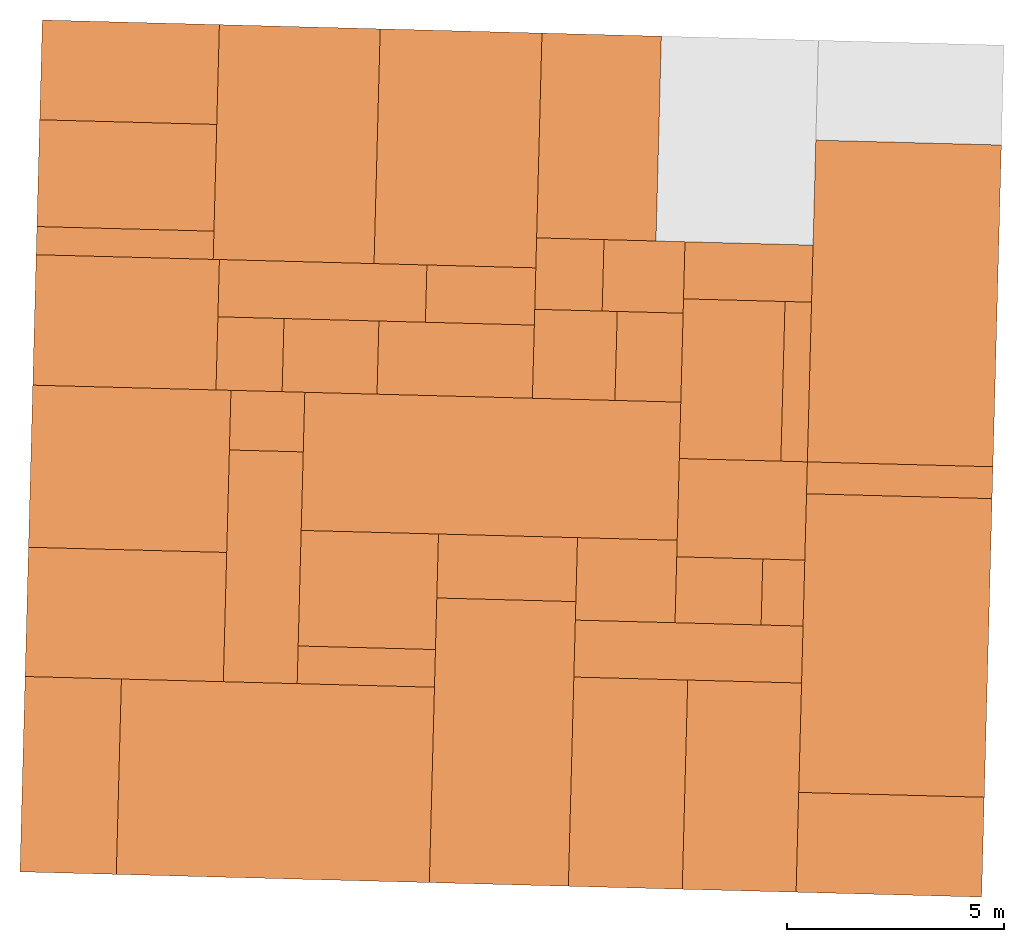
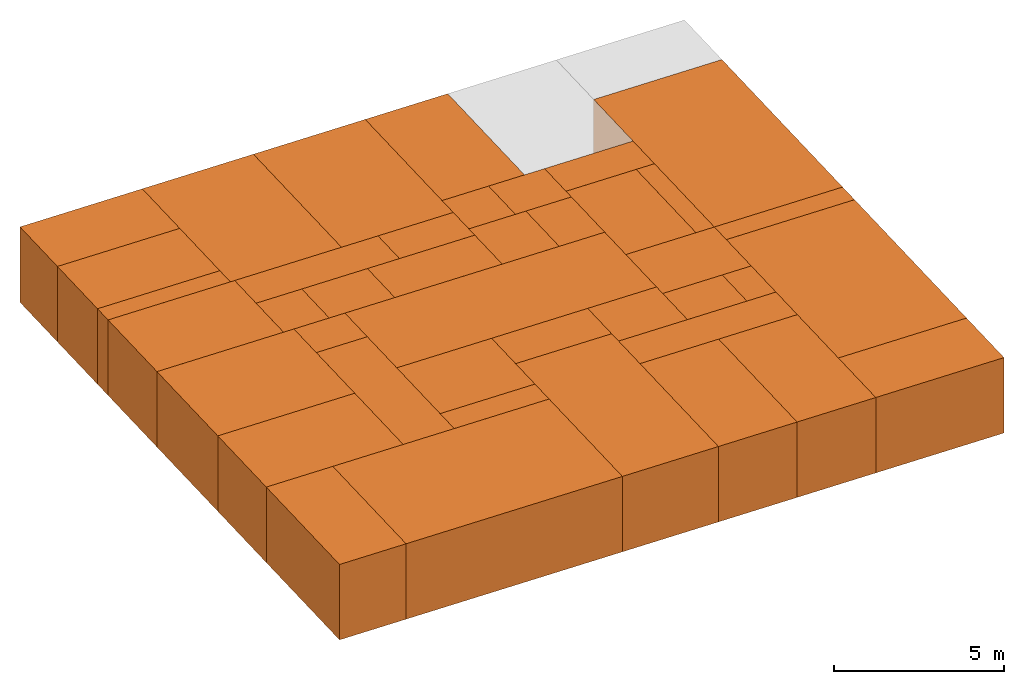
# One storey, part 1 of 2: 41 proxies.
"""IFC2X3 building model written with IfcOpenShell, lengths in metres."""

import ifcopenshell
import ifcopenshell.guid

model = None  # the IFC model being written
_history = None  # IfcOwnerHistory: only IFC2X3 demands one
_inside = {}  # id of a spatial element -> (the spatial element, [elements in it])
_under = {}  # id of a project, library or spatial element -> (it, [spatial elements below it])
_declared = {}  # id of a project -> (the project, [libraries it declares])
_typed = {}  # id of a type object -> (the type object, [elements of that type])
_made_of = {}  # id of a material, layer set ... -> (it, [elements and type objects made of it])


def new_model(schema):
    """Start an empty IFC model of exactly this schema.

    Asked for "IFC4X3", IfcOpenShell would pick the latest addendum, in which some entities
    have other attributes; the version numbers below select the first issue.
    IFC2X3 requires an IfcOwnerHistory on every rooted entity: one is made here for all.
    """
    global model, _history
    if schema == "IFC4X3":
        model = ifcopenshell.file(schema_version=(4, 3, 0, 0))
    else:
        model = ifcopenshell.file(schema=schema)
    _inside.clear()
    _under.clear()
    _declared.clear()
    _typed.clear()
    _made_of.clear()
    _history = None
    if model.schema == "IFC2X3":
        org = make("IfcOrganization", Name="unknown")
        user = make(
            "IfcPersonAndOrganization",
            ThePerson=make("IfcPerson", FamilyName="unknown"),
            TheOrganization=org,
        )
        app = make(
            "IfcApplication",
            ApplicationDeveloper=org,
            Version="unknown",
            ApplicationFullName="unknown",
            ApplicationIdentifier="unknown",
        )
        _history = make(
            "IfcOwnerHistory",
            OwningUser=user,
            OwningApplication=app,
            ChangeAction="ADDED",
            CreationDate=0,
        )
    return model


def make(cls, **values):
    """One entity of the class cls with the attributes given. An attribute that is None is left unset."""
    return model.create_entity(
        cls, **{name: value for name, value in values.items() if value is not None}
    )


def entity(cls, *values):
    """Any entity or typed value of the class cls, its attributes in the order of the schema. None: left unset."""
    e = model.create_entity(cls)
    for i, value in enumerate(values):
        if value is not None:
            e[i] = value
    return e


def rooted(cls, **values):
    """An entity with a GlobalId (a new one), such as an element, a storey or a relation."""
    return make(cls, GlobalId=ifcopenshell.guid.new(), OwnerHistory=_history, **values)


def si_unit(unit_type, name, prefix=None):
    """IfcSIUnit, for example si_unit("LENGTHUNIT", "METRE", prefix="MILLI")."""
    return make("IfcSIUnit", UnitType=unit_type, Prefix=prefix, Name=name)


def converted_unit(unit_type, name, factor, base, dimensions=None, offset=None):
    """IfcConversionBasedUnit, such as the inch: factor (a typed value) times the base unit."""
    return make(
        "IfcConversionBasedUnit"
        if offset is None
        else "IfcConversionBasedUnitWithOffset",
        ConversionOffset=offset,
        Dimensions=None
        if dimensions is None
        else entity("IfcDimensionalExponents", *dimensions),
        UnitType=unit_type,
        Name=name,
        ConversionFactor=make(
            "IfcMeasureWithUnit", ValueComponent=factor, UnitComponent=base
        ),
    )


def derived_unit(unit_type, elements):
    """IfcDerivedUnit: a product of units, each with its exponent."""
    return make(
        "IfcDerivedUnit",
        Elements=[
            make("IfcDerivedUnitElement", Unit=unit, Exponent=power)
            for unit, power in elements
        ],
        UnitType=unit_type,
    )


def assignment(units):
    """IfcUnitAssignment: the units of a project."""
    return None if units is None else make("IfcUnitAssignment", Units=units)


def point(xyz):
    """IfcCartesianPoint."""
    return None if xyz is None else make("IfcCartesianPoint", Coordinates=xyz)


def direction(xyz):
    """IfcDirection."""
    return None if xyz is None else make("IfcDirection", DirectionRatios=xyz)


def frame(location, z_axis=None, x_axis=None):
    """IfcAxis2Placement3D, a coordinate frame: its origin and axes. An axis left out is left unset."""
    return make(
        "IfcAxis2Placement3D",
        Location=point(location),
        Axis=direction(z_axis),
        RefDirection=direction(x_axis),
    )


def frame_2d(location, x_axis=None):
    """IfcAxis2Placement2D, a coordinate frame in the plane: its origin and x axis."""
    return make(
        "IfcAxis2Placement2D", Location=point(location), RefDirection=direction(x_axis)
    )


def origin():
    """The frame at (0, 0, 0) with its axes left unset."""
    return frame((0.0, 0.0, 0.0))


def origin_2d_with_axis():
    """The frame at (0, 0) in the plane with the x axis (1, 0) written out."""
    return frame_2d((0.0, 0.0), x_axis=(1.0, 0.0))


def place(relative_to, where):
    """IfcLocalPlacement: puts the frame where relative to a parent placement (None: the world)."""
    return make(
        "IfcLocalPlacement", PlacementRelTo=relative_to, RelativePlacement=where
    )


def context(
    kind, dimensions, precision=None, world=None, true_north=None, identifier=None
):
    """IfcGeometricRepresentationContext, for example the 3D "Model" context."""
    return make(
        "IfcGeometricRepresentationContext",
        ContextIdentifier=identifier,
        ContextType=kind,
        CoordinateSpaceDimension=dimensions,
        Precision=precision,
        WorldCoordinateSystem=world,
        TrueNorth=true_north,
    )


def subcontext(parent, identifier, kind, view, scale=None):
    """IfcGeometricRepresentationSubContext, for example "Body" below "Model"."""
    return make(
        "IfcGeometricRepresentationSubContext",
        ContextIdentifier=identifier,
        ContextType=kind,
        ParentContext=parent,
        TargetScale=scale,
        TargetView=view,
    )


def project(units=None, contexts=None):
    """IfcProject with its units and contexts."""
    return rooted(
        "IfcProject",
        Name="project",
        RepresentationContexts=contexts,
        UnitsInContext=assignment(units),
    )


def spatial(cls, under=None, at=None, **own):
    """A site, building, storey or space (cls), placed at a placement, below another one or the project."""
    s = rooted(cls, ObjectPlacement=at, **own)
    if under is not None:
        _under.setdefault(under.id(), (under, []))[1].append(s)
    return s


def profile(cls, at=None, kind="AREA", **sizes):
    """A parametric profile (cls). Its sizes go by their IFC names, for example OverallWidth=200.0."""
    return make(cls, ProfileType=kind, Position=at, **sizes)


def rectangle(**sizes):
    """IfcRectangleProfileDef."""
    return profile("IfcRectangleProfileDef", **sizes)


def extrude(swept, where, along, depth):
    """IfcExtrudedAreaSolid: the profile swept, set in the frame where, extruded along a direction by depth."""
    return make(
        "IfcExtrudedAreaSolid",
        SweptArea=swept,
        Position=where,
        ExtrudedDirection=direction(along),
        Depth=depth,
    )


def shape(context_of_items, identifier, shape_type, items):
    """IfcShapeRepresentation: the items that make up one representation, for example the "Body"."""
    return make(
        "IfcShapeRepresentation",
        ContextOfItems=context_of_items,
        RepresentationIdentifier=identifier,
        RepresentationType=shape_type,
        Items=items,
    )


def source(mapping_origin, context_of_items, identifier, shape_type, items):
    """IfcRepresentationMap: a shape defined once, which mapped items show again and again."""
    return make(
        "IfcRepresentationMap",
        MappingOrigin=mapping_origin,
        MappedRepresentation=shape(context_of_items, identifier, shape_type, items),
    )


def transform(
    local_origin,
    x_axis=None,
    y_axis=None,
    z_axis=None,
    scale=None,
    scale2=None,
    scale3=None,
    uniform=True,
):
    """IfcCartesianTransformationOperator3D, or its non-uniform kind. x_axis, y_axis, z_axis: its Axis1, 2, 3."""
    if uniform:
        return make(
            "IfcCartesianTransformationOperator3D",
            Axis1=direction(x_axis),
            Axis2=direction(y_axis),
            LocalOrigin=point(local_origin),
            Scale=scale,
            Axis3=direction(z_axis),
        )
    return make(
        "IfcCartesianTransformationOperator3DnonUniform",
        Axis1=direction(x_axis),
        Axis2=direction(y_axis),
        LocalOrigin=point(local_origin),
        Scale=scale,
        Axis3=direction(z_axis),
        Scale2=scale2,
        Scale3=scale3,
    )


def mapped(mapping_source, mapping_target):
    """IfcMappedItem: shows the shape of a source again, moved by a transform."""
    return make(
        "IfcMappedItem", MappingSource=mapping_source, MappingTarget=mapping_target
    )


def material(Name=None, Category=None):
    """IfcMaterial."""
    return make("IfcMaterial", Name=Name, Category=Category)


def made_of(thing, what):
    """Note that an element or type object is made of a material, layer set ...; save() writes the relation."""
    if what is not None:
        _made_of.setdefault(what.id(), (what, []))[1].append(thing)
    return thing


def type_object(cls, material=None, **own):
    """A type object (cls), such as IfcWallType, which elements share."""
    return made_of(rooted(cls, **own), material)


def type_shapes(of_type, sources):
    """Give a type object the sources (RepresentationMaps) that its elements show as mapped items."""
    of_type.RepresentationMaps = sources


def element(
    cls,
    number,
    at=None,
    inside=None,
    cuts=None,
    type_object=None,
    material=None,
    context=None,
    identifier="Body",
    shape_type=None,
    held_by="IfcProductDefinitionShape",
    body=None,
    shapes=None,
    **own,
):
    """One element of the class cls, such as IfcWall. Its Tag is "e" and its number.

    at: its placement. inside: the storey or other place that contains it. cuts: it is an
    opening in that element (IfcRelVoidsElement). A single representation is given by context,
    identifier, shape_type and body (its items); several are given by shapes. held_by: the class
    of the entity that holds the representations. save() writes the other relations.
    """
    e = rooted(cls, Tag="e%d" % number, ObjectPlacement=at, **own)
    if body is not None:
        shapes = [shape(context, identifier, shape_type, body)]
    if shapes is not None:
        e.Representation = make(held_by, Representations=shapes)
    if inside is not None:
        _inside.setdefault(inside.id(), (inside, []))[1].append(e)
    if cuts is not None:
        rooted(
            "IfcRelVoidsElement", RelatingBuildingElement=cuts, RelatedOpeningElement=e
        )
    if type_object is not None:
        _typed.setdefault(type_object.id(), (type_object, []))[1].append(e)
    return made_of(e, material)


def aggregate(whole, parts):
    """IfcRelAggregates: a whole, such as a stair, and the parts it consists of."""
    return rooted("IfcRelAggregates", RelatingObject=whole, RelatedObjects=parts)


def save(model, path):
    """Write the relations noted so far, then the file.

    IfcRelAggregates (storeys below a building ...), IfcRelContainedInSpatialStructure (elements
    in a storey), IfcRelDefinesByType, IfcRelAssociatesMaterial and IfcRelDeclares: one each for
    every whole, place, type object, material and project.
    """
    for whole, parts in _under.values():
        aggregate(whole, parts)
    for where, things in _inside.values():
        rooted(
            "IfcRelContainedInSpatialStructure",
            RelatedElements=things,
            RelatingStructure=where,
        )
    for kind, things in _typed.values():
        rooted("IfcRelDefinesByType", RelatedObjects=things, RelatingType=kind)
    for what, things in _made_of.values():
        rooted("IfcRelAssociatesMaterial", RelatedObjects=things, RelatingMaterial=what)
    for by, libraries in _declared.values():
        rooted("IfcRelDeclares", RelatingContext=by, RelatedDefinitions=libraries)
    model.write(path)


model = new_model("IFC2X3")

# Units and contexts
model_context = context("Model", 3, precision=1e-05, world=origin(), true_north=direction((-0.999656054706472, -0.0262254130318397)))
body_context = subcontext(model_context, "Body", "Model", "MODEL_VIEW")
ifc_project = project(units=[si_unit("LENGTHUNIT", "METRE"), si_unit("AREAUNIT", "SQUARE_METRE"), si_unit("VOLUMEUNIT", "CUBIC_METRE"), converted_unit("PLANEANGLEUNIT", "DEGREE", entity("IfcRatioMeasure", 0.0174532925199433), si_unit("PLANEANGLEUNIT", "RADIAN"), dimensions=[0, 0, 0, 0, 0, 0, 0]), si_unit("MASSUNIT", "GRAM", prefix="KILO"), derived_unit("MASSDENSITYUNIT", [(si_unit("MASSUNIT", "GRAM", prefix="KILO"), 1), (si_unit("LENGTHUNIT", "METRE"), -3)]), si_unit("TIMEUNIT", "SECOND"), si_unit("FREQUENCYUNIT", "HERTZ"), si_unit("THERMODYNAMICTEMPERATUREUNIT", "DEGREE_CELSIUS"), derived_unit("THERMALTRANSMITTANCEUNIT", [(si_unit("MASSUNIT", "GRAM", prefix="KILO"), 1), (si_unit("THERMODYNAMICTEMPERATUREUNIT", "KELVIN"), -1), (si_unit("TIMEUNIT", "SECOND"), -3)]), derived_unit("VOLUMETRICFLOWRATEUNIT", [(si_unit("LENGTHUNIT", "METRE"), 3), (si_unit("TIMEUNIT", "SECOND"), -1)]), si_unit("ELECTRICCURRENTUNIT", "AMPERE"), si_unit("ELECTRICVOLTAGEUNIT", "VOLT"), si_unit("POWERUNIT", "WATT"), si_unit("FORCEUNIT", "NEWTON", prefix="KILO"), si_unit("ILLUMINANCEUNIT", "LUX"), si_unit("LUMINOUSFLUXUNIT", "LUMEN"), si_unit("LUMINOUSINTENSITYUNIT", "CANDELA"), derived_unit("USERDEFINED", [(si_unit("MASSUNIT", "GRAM", prefix="KILO"), -1), (si_unit("LENGTHUNIT", "METRE"), -2), (si_unit("TIMEUNIT", "SECOND"), 3), (si_unit("LUMINOUSFLUXUNIT", "LUMEN"), 1)]), derived_unit("LINEARVELOCITYUNIT", [(si_unit("LENGTHUNIT", "METRE"), 1), (si_unit("TIMEUNIT", "SECOND"), -1)]), si_unit("PRESSUREUNIT", "PASCAL"), derived_unit("USERDEFINED", [(si_unit("LENGTHUNIT", "METRE"), -2), (si_unit("MASSUNIT", "GRAM", prefix="KILO"), 1), (si_unit("TIMEUNIT", "SECOND"), -2)])], contexts=[model_context])

# Site, building, storey
site_placement = place(None, frame((0.0, 0.0, 0.0), z_axis=(0.0, 0.0, 1.0), x_axis=(-0.0262254130318394, -0.999656054706472, 0.0)))
site = spatial("IfcSite", under=ifc_project, at=site_placement, CompositionType="ELEMENT")
building_placement = place(site_placement, origin())
building = spatial("IfcBuilding", under=site, at=building_placement, CompositionType="ELEMENT")
storey_placement = place(building_placement, origin())
storey = spatial("IfcBuildingStorey", under=building, at=storey_placement, Name="0EG", CompositionType="ELEMENT", Elevation=0.0)

# Proxies
ifc_material_1 = material(Name="010_DiningRoom")
building_element_proxy_type_1 = type_object("IfcBuildingElementProxyType", PredefinedType="NOTDEFINED", material=ifc_material_1)
shared_shape_1 = source(origin(), body_context, "Body", "SweptSolid", [
    extrude(rectangle(XDim=7.41911764705882, YDim=4.27941176470588, at=origin_2d_with_axis()), frame((0.0, 0.0, 0.0), z_axis=(0.0, 0.0, 1.0), x_axis=(-1.0, 0.0, 0.0)), (0.0, 0.0, 1.0), 2.7),
])
type_shapes(building_element_proxy_type_1, [shared_shape_1])
proxy_1_placement = place(storey_placement, frame((1.38045625640379, -30.1803742732614, 0.0)))
element("IfcBuildingElementProxy", 1, at=proxy_1_placement, inside=storey, type_object=building_element_proxy_type_1, material=ifc_material_1, Name="Segment_new:S", context=body_context, shape_type="MappedRepresentation", body=[
    mapped(shared_shape_1, transform((0.0, 0.0, 0.0), scale=1.0)),
])
building_element_proxy_type_2 = type_object("IfcBuildingElementProxyType", PredefinedType="NOTDEFINED", material=ifc_material_1)
shared_shape_2 = source(origin(), body_context, "Body", "SweptSolid", [
    extrude(rectangle(XDim=6.88676470588234, YDim=4.27941176470588, at=origin_2d_with_axis()), frame((0.0, 0.0, 0.0), z_axis=(0.0, 0.0, 1.0), x_axis=(-1.0, 0.0, 0.0)), (0.0, 0.0, 1.0), 2.7),
])
type_shapes(building_element_proxy_type_2, [shared_shape_2])
proxy_2_placement = place(storey_placement, frame((9.26869155052142, -30.1803742732615, 0.0)))
element("IfcBuildingElementProxy", 2, at=proxy_2_placement, inside=storey, type_object=building_element_proxy_type_2, material=ifc_material_1, Name="Segment_new:S", context=body_context, shape_type="MappedRepresentation", body=[
    mapped(shared_shape_2, transform((0.0, 0.0, 0.0), scale=1.0)),
])
ifc_material_2 = material(Name="004_Balcony")
building_element_proxy_type_3 = type_object("IfcBuildingElementProxyType", PredefinedType="NOTDEFINED", material=ifc_material_2)
shared_shape_3 = source(origin(), body_context, "Body", "SweptSolid", [
    extrude(rectangle(XDim=4.27941176470587, YDim=2.30147058823531, at=origin_2d_with_axis()), frame((0.0, 0.0, 0.0), z_axis=(0.0, 0.0, 1.0), x_axis=(0.0, 1.0, 0.0)), (0.0, 0.0, 1.0), 2.7),
])
type_shapes(building_element_proxy_type_3, [shared_shape_3])
proxy_3_placement = place(storey_placement, frame((13.8628091975802, -30.1803742732614, 0.0), z_axis=(0.0, 0.0, 1.0), x_axis=(-1.0, 0.0, 0.0)))
element("IfcBuildingElementProxy", 3, at=proxy_3_placement, inside=storey, type_object=building_element_proxy_type_3, material=ifc_material_2, Name="Segment_new:S", context=body_context, shape_type="MappedRepresentation", body=[
    mapped(shared_shape_3, transform((0.0, 0.0, 0.0), scale=1.0)),
])
ifc_material_3 = material(Name="002_Corridor")
building_element_proxy_type_4 = type_object("IfcBuildingElementProxyType", PredefinedType="NOTDEFINED", material=ifc_material_3)
shared_shape_4 = source(origin(), body_context, "Body", "SweptSolid", [
    extrude(rectangle(XDim=1.31617647058824, YDim=2.9529411764706, at=origin_2d_with_axis()), frame((0.0, 0.0, 0.0), z_axis=(0.0, 0.0, 1.0), x_axis=(-1.0, 0.0, 0.0)), (0.0, 0.0, 1.0), 2.7),
])
type_shapes(building_element_proxy_type_4, [shared_shape_4])
proxy_4_placement = place(storey_placement, frame((0.749573903462611, -33.7965507438497, 0.0)))
element("IfcBuildingElementProxy", 4, at=proxy_4_placement, inside=storey, type_object=building_element_proxy_type_4, material=ifc_material_3, Name="Segment_new:S", context=body_context, shape_type="MappedRepresentation", body=[
    mapped(shared_shape_4, transform((0.0, 0.0, 0.0), scale=1.0)),
])
ifc_material_4 = material(Name="001_Bedroom")
building_element_proxy_type_5 = type_object("IfcBuildingElementProxyType", PredefinedType="NOTDEFINED", material=ifc_material_4)
shared_shape_5 = source(origin(), body_context, "Body", "SweptSolid", [
    extrude(rectangle(XDim=4.72205882352941, YDim=2.75294117647059, at=origin_2d_with_axis()), frame((0.0, 0.0, 0.0), z_axis=(0.0, 0.0, 1.0), x_axis=(-1.0, 0.0, 0.0)), (0.0, 0.0, 1.0), 2.7),
])
type_shapes(building_element_proxy_type_5, [shared_shape_5])
proxy_5_placement = place(storey_placement, frame((-2.26954374359622, -37.3186095673791, 0.0)))
element("IfcBuildingElementProxy", 5, at=proxy_5_placement, inside=storey, type_object=building_element_proxy_type_5, material=ifc_material_4, Name="Segment_new:S_Sch", context=body_context, shape_type="MappedRepresentation", body=[
    mapped(shared_shape_5, transform((0.0, 0.0, 0.0), scale=1.0)),
])
building_element_proxy_type_6 = type_object("IfcBuildingElementProxyType", PredefinedType="NOTDEFINED", material=ifc_material_4)
shared_shape_6 = source(origin(), body_context, "Body", "SweptSolid", [
    extrude(rectangle(XDim=5.41323529411766, YDim=3.73088235294117, at=origin_2d_with_axis()), frame((0.0, 0.0, 0.0), z_axis=(0.0, 0.0, 1.0), x_axis=(-1.0, 0.0, 0.0)), (0.0, 0.0, 1.0), 2.7),
])
type_shapes(building_element_proxy_type_6, [shared_shape_6])
proxy_6_placement = place(storey_placement, frame((-1.9239555083021, -40.560521332085, 0.0)))
element("IfcBuildingElementProxy", 6, at=proxy_6_placement, inside=storey, type_object=building_element_proxy_type_6, material=ifc_material_4, Name="Segment_new:S_Sch", context=body_context, shape_type="MappedRepresentation", body=[
    mapped(shared_shape_6, transform((0.0, 0.0, 0.0), scale=1.0)),
])
building_element_proxy_type_7 = type_object("IfcBuildingElementProxyType", PredefinedType="NOTDEFINED", material=ifc_material_1)
shared_shape_7 = source(origin(), body_context, "Body", "SweptSolid", [
    extrude(rectangle(XDim=5.41323529411766, YDim=3.70882352941175, at=origin_2d_with_axis()), frame((0.0, 0.0, 0.0), z_axis=(0.0, 0.0, 1.0), x_axis=(-1.0, 0.0, 0.0)), (0.0, 0.0, 1.0), 2.7),
])
type_shapes(building_element_proxy_type_7, [shared_shape_7])
proxy_7_placement = place(storey_placement, frame((-1.92395550830211, -44.2803742732614, 0.0)))
element("IfcBuildingElementProxy", 7, at=proxy_7_placement, inside=storey, type_object=building_element_proxy_type_7, material=ifc_material_1, Name="Segment_new:S", context=body_context, shape_type="MappedRepresentation", body=[
    mapped(shared_shape_7, transform((0.0, 0.0, 0.0), scale=1.0)),
])
building_element_proxy_type_8 = type_object("IfcBuildingElementProxyType", PredefinedType="NOTDEFINED", material=ifc_material_2)
shared_shape_8 = source(origin(), body_context, "Body", "SweptSolid", [
    extrude(rectangle(XDim=4.08235294117649, YDim=2.30147058823531, at=origin_2d_with_axis()), frame((0.0, 0.0, 0.0), z_axis=(0.0, 0.0, 1.0), x_axis=(0.0, 1.0, 0.0)), (0.0, 0.0, 1.0), 2.7),
])
type_shapes(building_element_proxy_type_8, [shared_shape_8])
proxy_8_placement = place(storey_placement, frame((-3.47983786124327, -48.1759625085556, 0.0)))
element("IfcBuildingElementProxy", 8, at=proxy_8_placement, inside=storey, type_object=building_element_proxy_type_8, material=ifc_material_2, Name="Segment_new:S", context=body_context, shape_type="MappedRepresentation", body=[
    mapped(shared_shape_8, transform((0.0, 0.0, 0.0), scale=1.0)),
])
ifc_material_5 = material(Name="005_Kitchen")
building_element_proxy_type_9 = type_object("IfcBuildingElementProxyType", PredefinedType="NOTDEFINED", material=ifc_material_5)
shared_shape_9 = source(origin(), body_context, "Body", "SweptSolid", [
    extrude(rectangle(XDim=4.08235294117649, YDim=0.649999999999999, at=origin_2d_with_axis()), frame((0.0, 0.0, 0.0), z_axis=(0.0, 0.0, 1.0), x_axis=(0.0, 1.0, 0.0)), (0.0, 0.0, 1.0), 2.7),
])
type_shapes(building_element_proxy_type_9, [shared_shape_9])
proxy_9_placement = place(storey_placement, frame((0.457662138756726, -48.1759625085556, 0.0)))
element("IfcBuildingElementProxy", 9, at=proxy_9_placement, inside=storey, type_object=building_element_proxy_type_9, material=ifc_material_5, Name="Segment_new:S_Ins", context=body_context, shape_type="MappedRepresentation", body=[
    mapped(shared_shape_9, transform((0.0, 0.0, 0.0), scale=1.0)),
])
building_element_proxy_type_10 = type_object("IfcBuildingElementProxyType", PredefinedType="NOTDEFINED", material=ifc_material_4)
shared_shape_10 = source(origin(), body_context, "Body", "SweptSolid", [
    extrude(rectangle(XDim=4.22500000000002, YDim=3.00735294117647, at=origin_2d_with_axis()), frame((0.0, 0.0, 0.0), z_axis=(0.0, 0.0, 1.0), x_axis=(0.0, 1.0, 0.0)), (0.0, 0.0, 1.0), 2.7),
])
type_shapes(building_element_proxy_type_10, [shared_shape_10])
proxy_10_placement = place(storey_placement, frame((2.28633860934496, -48.1046389791438, 0.0)))
element("IfcBuildingElementProxy", 10, at=proxy_10_placement, inside=storey, type_object=building_element_proxy_type_10, material=ifc_material_4, Name="Segment_new:S_Sch", context=body_context, shape_type="MappedRepresentation", body=[
    mapped(shared_shape_10, transform((0.0, 0.0, 0.0), scale=1.0)),
])
building_element_proxy_type_11 = type_object("IfcBuildingElementProxyType", PredefinedType="NOTDEFINED", material=ifc_material_3)
shared_shape_11 = source(origin(), body_context, "Body", "SweptSolid", [
    extrude(rectangle(XDim=4.78529411764708, YDim=1.32058823529411, at=origin_2d_with_axis()), frame((0.0, 0.0, 0.0), z_axis=(0.0, 0.0, 1.0), x_axis=(0.0, 1.0, 0.0)), (0.0, 0.0, 1.0), 2.7),
])
type_shapes(building_element_proxy_type_11, [shared_shape_11])
proxy_11_placement = place(storey_placement, frame((1.44295625640379, -43.5994919203203, 0.0)))
element("IfcBuildingElementProxy", 11, at=proxy_11_placement, inside=storey, type_object=building_element_proxy_type_11, material=ifc_material_3, Name="Segment_new:S", context=body_context, shape_type="MappedRepresentation", body=[
    mapped(shared_shape_11, transform((0.0, 0.0, 0.0), scale=1.0)),
])
building_element_proxy_type_12 = type_object("IfcBuildingElementProxyType", PredefinedType="NOTDEFINED", material=ifc_material_3)
shared_shape_12 = source(origin(), body_context, "Body", "SweptSolid", [
    extrude(rectangle(XDim=2.18823529411765, YDim=1.68676470588235, at=origin_2d_with_axis()), frame((0.0, 0.0, 0.0), z_axis=(0.0, 0.0, 1.0), x_axis=(0.0, 1.0, 0.0)), (0.0, 0.0, 1.0), 2.7),
])
type_shapes(building_element_proxy_type_12, [shared_shape_12])
proxy_12_placement = place(storey_placement, frame((2.94663272699202, -43.373021332085, 0.0)))
element("IfcBuildingElementProxy", 12, at=proxy_12_placement, inside=storey, type_object=building_element_proxy_type_12, material=ifc_material_3, Name="Segment_new:S", context=body_context, shape_type="MappedRepresentation", body=[
    mapped(shared_shape_12, transform((0.0, 0.0, 0.0), scale=1.0)),
])
ifc_material_6 = material(Name="008_Roof")
building_element_proxy_type_13 = type_object("IfcBuildingElementProxyType", PredefinedType="NOTDEFINED", material=ifc_material_6)
shared_shape_13 = source(origin(), body_context, "Body", "SweptSolid", [
    extrude(rectangle(XDim=1.525, YDim=1.68676470588235, at=origin_2d_with_axis()), frame((0.0, 0.0, 0.0), z_axis=(0.0, 0.0, 1.0), x_axis=(0.0, 1.0, 0.0)), (0.0, 0.0, 1.0), 2.7),
])
type_shapes(building_element_proxy_type_13, [shared_shape_13])
proxy_13_placement = place(storey_placement, frame((2.94663272699202, -45.2296389791438, 0.0)))
element("IfcBuildingElementProxy", 13, at=proxy_13_placement, inside=storey, type_object=building_element_proxy_type_13, material=ifc_material_6, Name="Segment_new:S_Dac", context=body_context, shape_type="MappedRepresentation", body=[
    mapped(shared_shape_13, transform((0.0, 0.0, 0.0), scale=1.0)),
])
ifc_material_7 = material(Name="006_00_Bathroom_Shower")
building_element_proxy_type_14 = type_object("IfcBuildingElementProxyType", PredefinedType="NOTDEFINED", material=ifc_material_7)
shared_shape_14 = source(origin(), body_context, "Body", "SweptSolid", [
    extrude(rectangle(XDim=3.58382352941177, YDim=1.68676470588235, at=origin_2d_with_axis()), frame((0.0, 0.0, 0.0), z_axis=(0.0, 0.0, 1.0), x_axis=(0.0, 1.0, 0.0)), (0.0, 0.0, 1.0), 2.7),
])
type_shapes(building_element_proxy_type_14, [shared_shape_14])
proxy_14_placement = place(storey_placement, frame((2.94663272699203, -40.4869919203203, 0.0)))
element("IfcBuildingElementProxy", 14, at=proxy_14_placement, inside=storey, type_object=building_element_proxy_type_14, material=ifc_material_7, Name="Segment_new:S_Bad", context=body_context, shape_type="MappedRepresentation", body=[
    mapped(shared_shape_14, transform((0.0, 0.0, 0.0), scale=1.0)),
])
building_element_proxy_type_15 = type_object("IfcBuildingElementProxyType", PredefinedType="NOTDEFINED", material=ifc_material_7)
shared_shape_15 = source(origin(), body_context, "Body", "SweptSolid", [
    extrude(rectangle(XDim=2.51176470588236, YDim=1.32058823529412, at=frame_2d((-1.11022302462516e-16, 0.0), x_axis=(1.0, 0.0))), frame((0.0, 0.0, 0.0), z_axis=(0.0, 0.0, 1.0), x_axis=(0.0, 1.0, 0.0)), (0.0, 0.0, 1.0), 2.7),
])
type_shapes(building_element_proxy_type_15, [shared_shape_15])
proxy_15_placement = place(storey_placement, frame((1.44295625640379, -39.9509625085556, 0.0)))
element("IfcBuildingElementProxy", 15, at=proxy_15_placement, inside=storey, type_object=building_element_proxy_type_15, material=ifc_material_7, Name="Segment_new:S_Bad", context=body_context, shape_type="MappedRepresentation", body=[
    mapped(shared_shape_15, transform((0.0, 0.0, 0.0), scale=1.0)),
])
building_element_proxy_type_16 = type_object("IfcBuildingElementProxyType", PredefinedType="NOTDEFINED", material=ifc_material_7)
shared_shape_16 = source(origin(), body_context, "Body", "SweptSolid", [
    extrude(rectangle(XDim=2.34117647058825, YDim=3.68235294117647, at=origin_2d_with_axis()), frame((0.0, 0.0, 0.0), z_axis=(0.0, 0.0, 1.0), x_axis=(0.0, 1.0, 0.0)), (0.0, 0.0, 1.0), 2.7),
])
type_shapes(building_element_proxy_type_16, [shared_shape_16])
proxy_16_placement = place(storey_placement, frame((3.24883860934496, -34.1024330967909, 0.0)))
element("IfcBuildingElementProxy", 16, at=proxy_16_placement, inside=storey, type_object=building_element_proxy_type_16, material=ifc_material_7, Name="Segment_new:S_Bad", context=body_context, shape_type="MappedRepresentation", body=[
    mapped(shared_shape_16, transform((0.0, 0.0, 0.0), scale=1.0)),
])
building_element_proxy_type_17 = type_object("IfcBuildingElementProxyType", PredefinedType="NOTDEFINED", material=ifc_material_5)
shared_shape_17 = source(origin(), body_context, "Body", "SweptSolid", [
    extrude(rectangle(XDim=0.611764705882343, YDim=3.68235294117647, at=origin_2d_with_axis()), frame((0.0, 0.0, 0.0), z_axis=(0.0, 0.0, 1.0), x_axis=(0.0, 1.0, 0.0)), (0.0, 0.0, 1.0), 2.7),
])
type_shapes(building_element_proxy_type_17, [shared_shape_17])
proxy_17_placement = place(storey_placement, frame((3.24883860934497, -32.6259625085556, 0.0)))
element("IfcBuildingElementProxy", 17, at=proxy_17_placement, inside=storey, type_object=building_element_proxy_type_17, material=ifc_material_5, context=body_context, shape_type="MappedRepresentation", body=[
    mapped(shared_shape_17, transform((0.0, 0.0, 0.0), scale=1.0)),
])
building_element_proxy_type_18 = type_object("IfcBuildingElementProxyType", PredefinedType="NOTDEFINED", material=ifc_material_3)
shared_shape_18 = source(origin(), body_context, "Body", "SweptSolid", [
    extrude(rectangle(XDim=1.64705882352941, YDim=1.86764705882353, at=origin_2d_with_axis()), frame((0.0, 0.0, 0.0), z_axis=(0.0, 0.0, 1.0), x_axis=(-1.0, 0.0, 0.0)), (0.0, 0.0, 1.0), 2.7),
])
type_shapes(building_element_proxy_type_18, [shared_shape_18])
proxy_18_placement = place(storey_placement, frame((0.915015079933196, -36.2068448614967, 0.0)))
element("IfcBuildingElementProxy", 18, at=proxy_18_placement, inside=storey, type_object=building_element_proxy_type_18, material=ifc_material_3, Name="Segment_new:S", context=body_context, shape_type="MappedRepresentation", body=[
    mapped(shared_shape_18, transform((0.0, 0.0, 0.0), scale=1.0)),
])
ifc_material_8 = material(Name="003_LivingRoom")
building_element_proxy_type_19 = type_object("IfcBuildingElementProxyType", PredefinedType="NOTDEFINED", material=ifc_material_8)
shared_shape_19 = source(origin(), body_context, "Body", "SweptSolid", [
    extrude(rectangle(XDim=1.64705882352941, YDim=1.55441176470586, at=origin_2d_with_axis()), frame((0.0, 0.0, 0.0), z_axis=(0.0, 0.0, 1.0), x_axis=(-1.0, 0.0, 0.0)), (0.0, 0.0, 1.0), 2.7),
])
type_shapes(building_element_proxy_type_19, [shared_shape_19])
proxy_19_placement = place(storey_placement, frame((0.915015079933193, -37.9178742732614, 0.0)))
element("IfcBuildingElementProxy", 19, at=proxy_19_placement, inside=storey, type_object=building_element_proxy_type_19, material=ifc_material_8, Name="Segment_new:S", context=body_context, shape_type="MappedRepresentation", body=[
    mapped(shared_shape_19, transform((0.0, 0.0, 0.0), scale=1.0)),
])
building_element_proxy_type_20 = type_object("IfcBuildingElementProxyType", PredefinedType="NOTDEFINED", material=ifc_material_8)
shared_shape_20 = source(origin(), body_context, "Body", "SweptSolid", [
    extrude(rectangle(XDim=2.05147058823529, YDim=1.90294117647058, at=origin_2d_with_axis()), frame((0.0, 0.0, 0.0), z_axis=(0.0, 0.0, 1.0), x_axis=(-1.0, 0.0, 0.0)), (0.0, 0.0, 1.0), 2.7),
])
type_shapes(building_element_proxy_type_20, [shared_shape_20])
proxy_20_placement = place(storey_placement, frame((2.76427978581555, -37.7436095673791, 0.0)))
element("IfcBuildingElementProxy", 20, at=proxy_20_placement, inside=storey, type_object=building_element_proxy_type_20, material=ifc_material_8, Name="Segment_new:S", context=body_context, shape_type="MappedRepresentation", body=[
    mapped(shared_shape_20, transform((0.0, 0.0, 0.0), scale=1.0)),
])
building_element_proxy_type_21 = type_object("IfcBuildingElementProxyType", PredefinedType="NOTDEFINED", material=ifc_material_3)
shared_shape_21 = source(origin(), body_context, "Body", "SweptSolid", [
    extrude(rectangle(XDim=2.05147058823529, YDim=1.51911764705881, at=origin_2d_with_axis()), frame((0.0, 0.0, 0.0), z_axis=(0.0, 0.0, 1.0), x_axis=(-1.0, 0.0, 0.0)), (0.0, 0.0, 1.0), 2.7),
])
type_shapes(building_element_proxy_type_21, [shared_shape_21])
proxy_21_placement = place(storey_placement, frame((2.76427978581555, -36.0325801556144, 0.0)))
element("IfcBuildingElementProxy", 21, at=proxy_21_placement, inside=storey, type_object=building_element_proxy_type_21, material=ifc_material_3, Name="Segment_new:S", context=body_context, shape_type="MappedRepresentation", body=[
    mapped(shared_shape_21, transform((0.0, 0.0, 0.0), scale=1.0)),
])
building_element_proxy_type_22 = type_object("IfcBuildingElementProxyType", PredefinedType="NOTDEFINED", material=ifc_material_4)
shared_shape_22 = source(origin(), body_context, "Body", "SweptSolid", [
    extrude(rectangle(XDim=4.82352941176472, YDim=2.62499999999997, at=origin_2d_with_axis()), frame((0.0, 0.0, 0.0), z_axis=(0.0, 0.0, 1.0), x_axis=(-1.0, 0.0, 0.0)), (0.0, 0.0, 1.0), 2.7),
])
type_shapes(building_element_proxy_type_22, [shared_shape_22])
proxy_22_placement = place(storey_placement, frame((12.6017797858156, -33.6325801556144, 0.0)))
element("IfcBuildingElementProxy", 22, at=proxy_22_placement, inside=storey, type_object=building_element_proxy_type_22, material=ifc_material_4, Name="Segment_new:S_Sch", context=body_context, shape_type="MappedRepresentation", body=[
    mapped(shared_shape_22, transform((0.0, 0.0, 0.0), scale=1.0)),
])
building_element_proxy_type_23 = type_object("IfcBuildingElementProxyType", PredefinedType="NOTDEFINED", material=ifc_material_4)
shared_shape_23 = source(origin(), body_context, "Body", "SweptSolid", [
    extrude(rectangle(XDim=4.82352941176472, YDim=2.62647058823531, at=origin_2d_with_axis()), frame((0.0, 0.0, 0.0), z_axis=(0.0, 0.0, 1.0), x_axis=(-1.0, 0.0, 0.0)), (0.0, 0.0, 1.0), 2.7),
])
type_shapes(building_element_proxy_type_23, [shared_shape_23])
proxy_23_placement = place(storey_placement, frame((12.6017797858156, -36.258315449732, 0.0)))
element("IfcBuildingElementProxy", 23, at=proxy_23_placement, inside=storey, type_object=building_element_proxy_type_23, material=ifc_material_4, Name="Segment_new:S_Sch", context=body_context, shape_type="MappedRepresentation", body=[
    mapped(shared_shape_23, transform((0.0, 0.0, 0.0), scale=1.0)),
])
building_element_proxy_type_24 = type_object("IfcBuildingElementProxyType", PredefinedType="NOTDEFINED", material=ifc_material_3)
shared_shape_24 = source(origin(), body_context, "Body", "SweptSolid", [
    extrude(rectangle(XDim=1.31323529411764, YDim=5.25147058823529, at=origin_2d_with_axis()), frame((0.0, 0.0, 0.0), z_axis=(0.0, 0.0, 1.0), x_axis=(-1.0, 0.0, 0.0)), (0.0, 0.0, 1.0), 2.7),
])
type_shapes(building_element_proxy_type_24, [shared_shape_24])
proxy_24_placement = place(storey_placement, frame((9.53339743287437, -34.9458154497321, 0.0)))
element("IfcBuildingElementProxy", 24, at=proxy_24_placement, inside=storey, type_object=building_element_proxy_type_24, material=ifc_material_3, Name="Segment_new:S", context=body_context, shape_type="MappedRepresentation", body=[
    mapped(shared_shape_24, transform((0.0, 0.0, 0.0), scale=1.0)),
])
building_element_proxy_type_25 = type_object("IfcBuildingElementProxyType", PredefinedType="NOTDEFINED", material=ifc_material_3)
shared_shape_25 = source(origin(), body_context, "Body", "SweptSolid", [
    extrude(rectangle(XDim=1.90147058823529, YDim=2.29852941176471, at=origin_2d_with_axis()), frame((0.0, 0.0, 0.0), z_axis=(0.0, 0.0, 1.0), x_axis=(-1.0, 0.0, 0.0)), (0.0, 0.0, 1.0), 2.7),
])
type_shapes(building_element_proxy_type_25, [shared_shape_25])
proxy_25_placement = place(storey_placement, frame((7.9260444916979, -36.4222860379673, 0.0)))
element("IfcBuildingElementProxy", 25, at=proxy_25_placement, inside=storey, type_object=building_element_proxy_type_25, material=ifc_material_3, Name="Segment_new:S", context=body_context, shape_type="MappedRepresentation", body=[
    mapped(shared_shape_25, transform((0.0, 0.0, 0.0), scale=1.0)),
])
building_element_proxy_type_26 = type_object("IfcBuildingElementProxyType", PredefinedType="NOTDEFINED", material=ifc_material_4)
shared_shape_26 = source(origin(), body_context, "Body", "SweptSolid", [
    extrude(rectangle(XDim=6.56323529411764, YDim=3.20588235294116, at=origin_2d_with_axis()), frame((0.0, 0.0, 0.0), z_axis=(0.0, 0.0, 1.0), x_axis=(-1.0, 0.0, 0.0)), (0.0, 0.0, 1.0), 2.7),
])
type_shapes(building_element_proxy_type_26, [shared_shape_26])
proxy_26_placement = place(storey_placement, frame((11.7319268446391, -39.1744919203203, 0.0)))
element("IfcBuildingElementProxy", 26, at=proxy_26_placement, inside=storey, type_object=building_element_proxy_type_26, material=ifc_material_4, Name="Segment_new:S_Sch", context=body_context, shape_type="MappedRepresentation", body=[
    mapped(shared_shape_26, transform((0.0, 0.0, 0.0), scale=1.0)),
])
building_element_proxy_type_27 = type_object("IfcBuildingElementProxyType", PredefinedType="NOTDEFINED", material=ifc_material_7)
shared_shape_27 = source(origin(), body_context, "Body", "SweptSolid", [
    extrude(rectangle(XDim=3.20588235294117, YDim=1.47500000000001, at=origin_2d_with_axis()), frame((0.0, 0.0, 0.0), z_axis=(0.0, 0.0, 1.0), x_axis=(0.0, 1.0, 0.0)), (0.0, 0.0, 1.0), 2.7),
])
type_shapes(building_element_proxy_type_27, [shared_shape_27])
proxy_27_placement = place(storey_placement, frame((7.71280919758026, -39.1744919203203, 0.0)))
element("IfcBuildingElementProxy", 27, at=proxy_27_placement, inside=storey, type_object=building_element_proxy_type_27, material=ifc_material_7, Name="Segment_new:S_Bad", context=body_context, shape_type="MappedRepresentation", body=[
    mapped(shared_shape_27, transform((0.0, 0.0, 0.0), scale=1.0)),
])
building_element_proxy_type_28 = type_object("IfcBuildingElementProxyType", PredefinedType="NOTDEFINED", material=ifc_material_7)
shared_shape_28 = source(origin(), body_context, "Body", "SweptSolid", [
    extrude(rectangle(XDim=2.9529411764706, YDim=2.26617647058823, at=origin_2d_with_axis()), frame((0.0, 0.0, 0.0), z_axis=(0.0, 0.0, 1.0), x_axis=(0.0, 1.0, 0.0)), (0.0, 0.0, 1.0), 2.7),
])
type_shapes(building_element_proxy_type_28, [shared_shape_28])
proxy_28_placement = place(storey_placement, frame((6.22310331522732, -33.7965507438497, 0.0)))
element("IfcBuildingElementProxy", 28, at=proxy_28_placement, inside=storey, type_object=building_element_proxy_type_28, material=ifc_material_7, Name="Segment_new:S_Bad", context=body_context, shape_type="MappedRepresentation", body=[
    mapped(shared_shape_28, transform((0.0, 0.0, 0.0), scale=1.0)),
])
building_element_proxy_type_29 = type_object("IfcBuildingElementProxyType", PredefinedType="NOTDEFINED", material=ifc_material_7)
shared_shape_29 = source(origin(), body_context, "Body", "SweptSolid", [
    extrude(rectangle(XDim=1.98529411764705, YDim=1.52058823529412, at=origin_2d_with_axis()), frame((0.0, 0.0, 0.0), z_axis=(0.0, 0.0, 1.0), x_axis=(0.0, 1.0, 0.0)), (0.0, 0.0, 1.0), 2.7),
])
type_shapes(building_element_proxy_type_29, [shared_shape_29])
proxy_29_placement = place(storey_placement, frame((8.11648566816849, -34.2803742732615, 0.0)))
element("IfcBuildingElementProxy", 29, at=proxy_29_placement, inside=storey, type_object=building_element_proxy_type_29, material=ifc_material_7, Name="Segment_new:S_Bad", context=body_context, shape_type="MappedRepresentation", body=[
    mapped(shared_shape_29, transform((0.0, 0.0, 0.0), scale=1.0)),
])
building_element_proxy_type_30 = type_object("IfcBuildingElementProxyType", PredefinedType="NOTDEFINED", material=ifc_material_6)
shared_shape_30 = source(origin(), body_context, "Body", "SweptSolid", [
    extrude(rectangle(XDim=0.967647058823531, YDim=1.52058823529412, at=frame_2d((0.0, -5.55111512312578e-17), x_axis=(1.0, 0.0))), frame((0.0, 0.0, 0.0), z_axis=(0.0, 0.0, 1.0), x_axis=(0.0, 1.0, 0.0)), (0.0, 0.0, 1.0), 2.7),
])
type_shapes(building_element_proxy_type_30, [shared_shape_30])
proxy_30_placement = place(storey_placement, frame((8.11648566816849, -32.8039036850262, 0.0)))
element("IfcBuildingElementProxy", 30, at=proxy_30_placement, inside=storey, type_object=building_element_proxy_type_30, material=ifc_material_6, Name="Segment_new:S_Dac", context=body_context, shape_type="MappedRepresentation", body=[
    mapped(shared_shape_30, transform((0.0, 0.0, 0.0), scale=1.0)),
])
ifc_material_9 = material(Name="017")
building_element_proxy_type_31 = type_object("IfcBuildingElementProxyType", PredefinedType="NOTDEFINED", material=ifc_material_9)
shared_shape_31 = source(origin(), body_context, "Body", "SweptSolid", [
    extrude(rectangle(XDim=3.18529411764706, YDim=8.67058823529413, at=frame_2d((0.0, -4.44089209850063e-16), x_axis=(1.0, 0.0))), frame((0.0, 0.0, 0.0), z_axis=(0.0, 0.0, 1.0), x_axis=(-1.0, 0.0, 0.0)), (0.0, 0.0, 1.0), 2.7),
])
type_shapes(building_element_proxy_type_31, [shared_shape_31])
proxy_31_placement = place(storey_placement, frame((5.38266213875671, -39.608315449732, 0.0)))
element("IfcBuildingElementProxy", 31, at=proxy_31_placement, inside=storey, type_object=building_element_proxy_type_31, material=ifc_material_9, Name="Segment_new:S_Tre", context=body_context, shape_type="MappedRepresentation", body=[
    mapped(shared_shape_31, transform((0.0, 0.0, 0.0), scale=1.0)),
])
building_element_proxy_type_32 = type_object("IfcBuildingElementProxyType", PredefinedType="NOTDEFINED", material=ifc_material_7)
shared_shape_32 = source(origin(), body_context, "Body", "SweptSolid", [
    extrude(rectangle(XDim=3.16617647058826, YDim=2.66470588235295, at=origin_2d_with_axis()), frame((0.0, 0.0, 0.0), z_axis=(0.0, 0.0, 1.0), x_axis=(0.0, 1.0, 0.0)), (0.0, 0.0, 1.0), 2.7),
])
type_shapes(building_element_proxy_type_32, [shared_shape_32])
proxy_32_placement = place(storey_placement, frame((8.30766213875672, -42.360521332085, 0.0)))
element("IfcBuildingElementProxy", 32, at=proxy_32_placement, inside=storey, type_object=building_element_proxy_type_32, material=ifc_material_7, Name="Segment_new:S_Bad", context=body_context, shape_type="MappedRepresentation", body=[
    mapped(shared_shape_32, transform((0.0, 0.0, 0.0), scale=1.0)),
])
building_element_proxy_type_33 = type_object("IfcBuildingElementProxyType", PredefinedType="NOTDEFINED", material=ifc_material_5)
shared_shape_33 = source(origin(), body_context, "Body", "SweptSolid", [
    extrude(rectangle(XDim=3.16617647058822, YDim=0.869117647058837, at=origin_2d_with_axis()), frame((0.0, 0.0, 0.0), z_axis=(0.0, 0.0, 1.0), x_axis=(0.0, 1.0, 0.0)), (0.0, 0.0, 1.0), 2.7),
])
type_shapes(building_element_proxy_type_33, [shared_shape_33])
proxy_33_placement = place(storey_placement, frame((10.0745739034626, -42.360521332085, 0.0)))
element("IfcBuildingElementProxy", 33, at=proxy_33_placement, inside=storey, type_object=building_element_proxy_type_33, material=ifc_material_5, context=body_context, shape_type="MappedRepresentation", body=[
    mapped(shared_shape_33, transform((0.0, 0.0, 0.0), scale=1.0)),
])
building_element_proxy_type_34 = type_object("IfcBuildingElementProxyType", PredefinedType="NOTDEFINED", material=ifc_material_1)
shared_shape_34 = source(origin(), body_context, "Body", "SweptSolid", [
    extrude(rectangle(XDim=4.50441176470587, YDim=7.2191176470588, at=origin_2d_with_axis()), frame((0.0, 0.0, 0.0), z_axis=(0.0, 0.0, 1.0), x_axis=(-1.0, 0.0, 0.0)), (0.0, 0.0, 1.0), 2.7),
])
type_shapes(building_element_proxy_type_34, [shared_shape_34])
proxy_34_placement = place(storey_placement, frame((12.761338609345, -44.3869919203203, 0.0)))
element("IfcBuildingElementProxy", 34, at=proxy_34_placement, inside=storey, type_object=building_element_proxy_type_34, material=ifc_material_1, Name="Segment_new:S", context=body_context, shape_type="MappedRepresentation", body=[
    mapped(shared_shape_34, transform((0.0, 0.0, 0.0), scale=1.0)),
])
building_element_proxy_type_35 = type_object("IfcBuildingElementProxyType", PredefinedType="NOTDEFINED", material=ifc_material_2)
shared_shape_35 = source(origin(), body_context, "Body", "SweptSolid", [
    extrude(rectangle(XDim=2.22058823529411, YDim=4.50441176470587, at=origin_2d_with_axis()), frame((0.0, 0.0, 0.0), z_axis=(0.0, 0.0, 1.0), x_axis=(0.0, 1.0, 0.0)), (0.0, 0.0, 1.0), 2.7),
])
type_shapes(building_element_proxy_type_35, [shared_shape_35])
proxy_35_placement = place(storey_placement, frame((12.761338609345, -49.1068448614967, 0.0)))
element("IfcBuildingElementProxy", 35, at=proxy_35_placement, inside=storey, type_object=building_element_proxy_type_35, material=ifc_material_2, Name="Segment_new:S", context=body_context, shape_type="MappedRepresentation", body=[
    mapped(shared_shape_35, transform((0.0, 0.0, 0.0), scale=1.0)),
])
building_element_proxy_type_36 = type_object("IfcBuildingElementProxyType", PredefinedType="NOTDEFINED", material=ifc_material_6)
shared_shape_36 = source(origin(), body_context, "Body", "SweptSolid", [
    extrude(rectangle(XDim=1.7029411764706, YDim=1.37500000000002, at=origin_2d_with_axis()), frame((0.0, 0.0, 0.0), z_axis=(0.0, 0.0, 1.0), x_axis=(0.0, 1.0, 0.0)), (0.0, 0.0, 1.0), 2.7),
])
type_shapes(building_element_proxy_type_36, [shared_shape_36])
proxy_36_placement = place(storey_placement, frame((4.47751507993319, -44.7950801556144, 0.0)))
element("IfcBuildingElementProxy", 36, at=proxy_36_placement, inside=storey, type_object=building_element_proxy_type_36, material=ifc_material_6, Name="Segment_new:S_Dac", context=body_context, shape_type="MappedRepresentation", body=[
    mapped(shared_shape_36, transform((0.0, 0.0, 0.0), scale=1.0)),
])
building_element_proxy_type_37 = type_object("IfcBuildingElementProxyType", PredefinedType="NOTDEFINED", material=ifc_material_3)
shared_shape_37 = source(origin(), body_context, "Body", "SweptSolid", [
    extrude(rectangle(XDim=1.7029411764706, YDim=5.34411764705883, at=origin_2d_with_axis()), frame((0.0, 0.0, 0.0), z_axis=(0.0, 0.0, 1.0), x_axis=(0.0, 1.0, 0.0)), (0.0, 0.0, 1.0), 2.7),
])
type_shapes(building_element_proxy_type_37, [shared_shape_37])
proxy_37_placement = place(storey_placement, frame((7.83707390346262, -44.7950801556144, 0.0)))
element("IfcBuildingElementProxy", 37, at=proxy_37_placement, inside=storey, type_object=building_element_proxy_type_37, material=ifc_material_3, Name="Segment_new:S", context=body_context, shape_type="MappedRepresentation", body=[
    mapped(shared_shape_37, transform((0.0, 0.0, 0.0), scale=1.0)),
])
building_element_proxy_type_38 = type_object("IfcBuildingElementProxyType", PredefinedType="NOTDEFINED", material=ifc_material_4)
shared_shape_38 = source(origin(), body_context, "Body", "SweptSolid", [
    extrude(rectangle(XDim=3.73823529411768, YDim=4.57058823529412, at=origin_2d_with_axis()), frame((0.0, 0.0, 0.0), z_axis=(0.0, 0.0, 1.0), x_axis=(-1.0, 0.0, 0.0)), (0.0, 0.0, 1.0), 2.7),
])
type_shapes(building_element_proxy_type_38, [shared_shape_38])
proxy_38_placement = place(storey_placement, frame((5.65913272699201, -47.9318448614968, 0.0)))
element("IfcBuildingElementProxy", 38, at=proxy_38_placement, inside=storey, type_object=building_element_proxy_type_38, material=ifc_material_4, Name="Segment_new:S_Sch", context=body_context, shape_type="MappedRepresentation", body=[
    mapped(shared_shape_38, transform((0.0, 0.0, 0.0), scale=1.0)),
])
building_element_proxy_type_39 = type_object("IfcBuildingElementProxyType", PredefinedType="NOTDEFINED", material=ifc_material_4)
shared_shape_39 = source(origin(), body_context, "Body", "SweptSolid", [
    extrude(rectangle(XDim=2.98088235294117, YDim=4.57058823529412, at=origin_2d_with_axis()), frame((0.0, 0.0, 0.0), z_axis=(0.0, 0.0, 1.0), x_axis=(-1.0, 0.0, 0.0)), (0.0, 0.0, 1.0), 2.7),
])
type_shapes(building_element_proxy_type_39, [shared_shape_39])
proxy_39_placement = place(storey_placement, frame((9.01869155052143, -47.9318448614968, 0.0)))
element("IfcBuildingElementProxy", 39, at=proxy_39_placement, inside=storey, type_object=building_element_proxy_type_39, material=ifc_material_4, Name="Segment_new:S_Sch", context=body_context, shape_type="MappedRepresentation", body=[
    mapped(shared_shape_39, transform((0.0, 0.0, 0.0), scale=1.0)),
])
building_element_proxy_type_40 = type_object("IfcBuildingElementProxyType", PredefinedType="NOTDEFINED", material=ifc_material_1)
shared_shape_40 = source(origin(), body_context, "Body", "SweptSolid", [
    extrude(rectangle(XDim=4.08235294117649, YDim=2.46176470588235, at=origin_2d_with_axis()), frame((0.0, 0.0, 0.0), z_axis=(0.0, 0.0, 1.0), x_axis=(0.0, 1.0, 0.0)), (0.0, 0.0, 1.0), 2.7),
])
type_shapes(building_element_proxy_type_40, [shared_shape_40])
proxy_40_placement = place(storey_placement, frame((-1.09822021418445, -48.1759625085556, 0.0)))
element("IfcBuildingElementProxy", 40, at=proxy_40_placement, inside=storey, type_object=building_element_proxy_type_40, material=ifc_material_1, Name="Segment_new:S", context=body_context, shape_type="MappedRepresentation", body=[
    mapped(shared_shape_40, transform((0.0, 0.0, 0.0), scale=1.0)),
])
building_element_proxy_type_41 = type_object("IfcBuildingElementProxyType", PredefinedType="NOTDEFINED", material=ifc_material_5)
shared_shape_41 = source(origin(), body_context, "Body", "SweptSolid", [
    extrude(rectangle(XDim=4.27941176470588, YDim=0.735294117647064, at=origin_2d_with_axis()), frame((0.0, 0.0, 0.0), z_axis=(0.0, 0.0, 1.0), x_axis=(0.0, 1.0, 0.0)), (0.0, 0.0, 1.0), 2.7),
])
type_shapes(building_element_proxy_type_41, [shared_shape_41])
proxy_41_placement = place(storey_placement, frame((5.45766213875672, -30.1803742732615, 0.0)))
element("IfcBuildingElementProxy", 41, at=proxy_41_placement, inside=storey, type_object=building_element_proxy_type_41, material=ifc_material_5, context=body_context, shape_type="MappedRepresentation", body=[
    mapped(shared_shape_41, transform((0.0, 0.0, 0.0), scale=1.0)),
])

save(model, "model.ifc")
